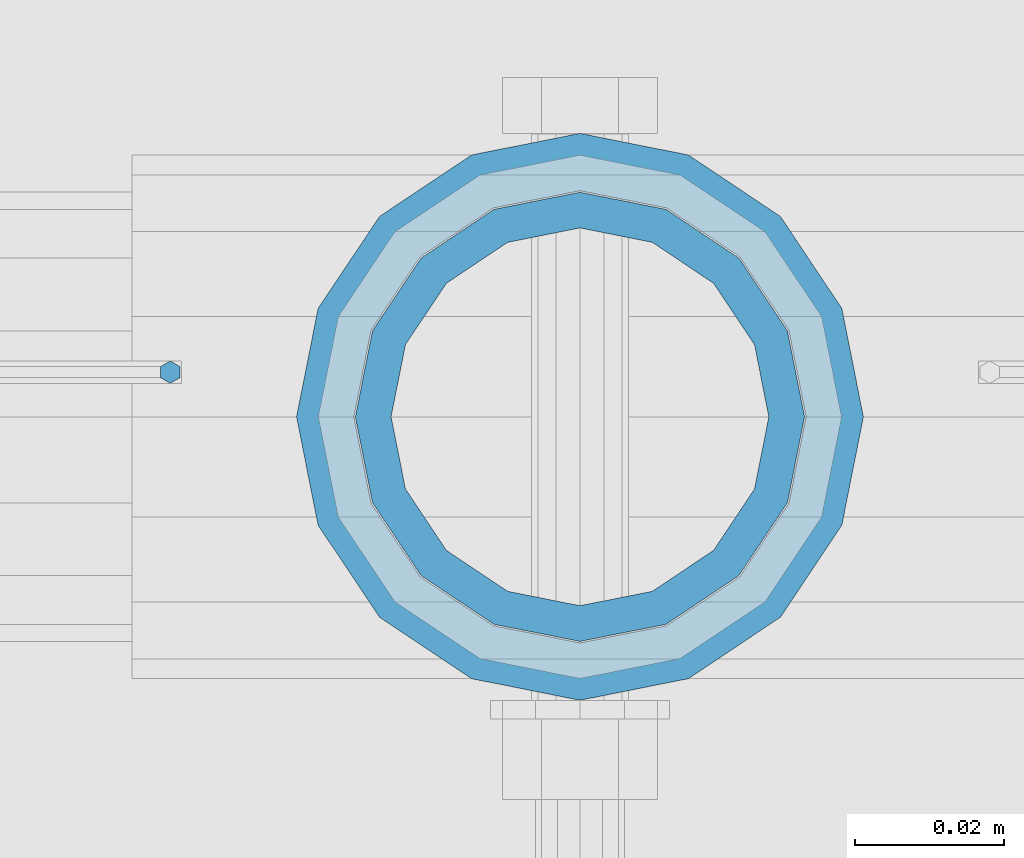
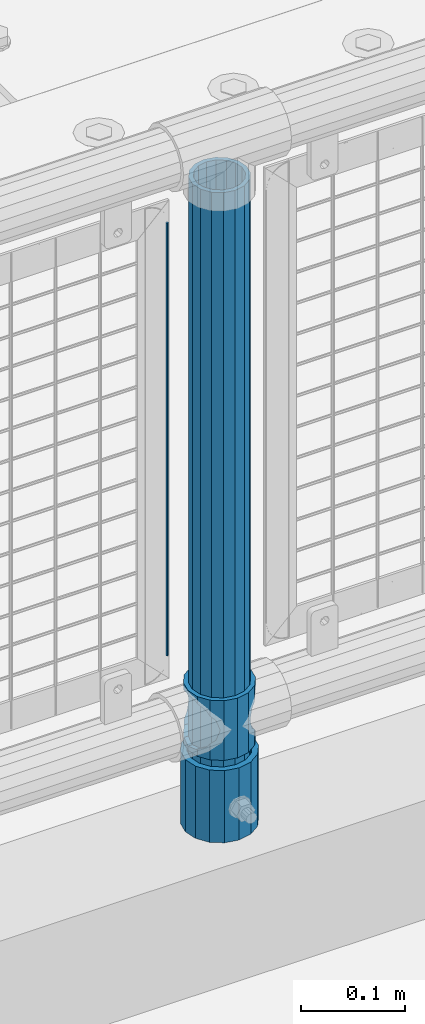
# One storey, part 82 of 247: 4 columns.
"""IFC2X3 building model written with IfcOpenShell, lengths in millimetres."""

import ifcopenshell
import ifcopenshell.guid

model = None  # the IFC model being written
_history = None  # IfcOwnerHistory: only IFC2X3 demands one
_inside = {}  # id of a spatial element -> (the spatial element, [elements in it])
_under = {}  # id of a project, library or spatial element -> (it, [spatial elements below it])
_declared = {}  # id of a project -> (the project, [libraries it declares])
_typed = {}  # id of a type object -> (the type object, [elements of that type])
_made_of = {}  # id of a material, layer set ... -> (it, [elements and type objects made of it])


def new_model(schema):
    """Start an empty IFC model of exactly this schema.

    Asked for "IFC4X3", IfcOpenShell would pick the latest addendum, in which some entities
    have other attributes; the version numbers below select the first issue.
    IFC2X3 requires an IfcOwnerHistory on every rooted entity: one is made here for all.
    """
    global model, _history
    if schema == "IFC4X3":
        model = ifcopenshell.file(schema_version=(4, 3, 0, 0))
    else:
        model = ifcopenshell.file(schema=schema)
    _inside.clear()
    _under.clear()
    _declared.clear()
    _typed.clear()
    _made_of.clear()
    _history = None
    if model.schema == "IFC2X3":
        org = make("IfcOrganization", Name="unknown")
        user = make(
            "IfcPersonAndOrganization",
            ThePerson=make("IfcPerson", FamilyName="unknown"),
            TheOrganization=org,
        )
        app = make(
            "IfcApplication",
            ApplicationDeveloper=org,
            Version="unknown",
            ApplicationFullName="unknown",
            ApplicationIdentifier="unknown",
        )
        _history = make(
            "IfcOwnerHistory",
            OwningUser=user,
            OwningApplication=app,
            ChangeAction="ADDED",
            CreationDate=0,
        )
    return model


def make(cls, **values):
    """One entity of the class cls with the attributes given. An attribute that is None is left unset."""
    return model.create_entity(
        cls, **{name: value for name, value in values.items() if value is not None}
    )


def rooted(cls, **values):
    """An entity with a GlobalId (a new one), such as an element, a storey or a relation."""
    return make(cls, GlobalId=ifcopenshell.guid.new(), OwnerHistory=_history, **values)


def si_unit(unit_type, name, prefix=None):
    """IfcSIUnit, for example si_unit("LENGTHUNIT", "METRE", prefix="MILLI")."""
    return make("IfcSIUnit", UnitType=unit_type, Prefix=prefix, Name=name)


def assignment(units):
    """IfcUnitAssignment: the units of a project."""
    return None if units is None else make("IfcUnitAssignment", Units=units)


def point(xyz):
    """IfcCartesianPoint."""
    return None if xyz is None else make("IfcCartesianPoint", Coordinates=xyz)


def direction(xyz):
    """IfcDirection."""
    return None if xyz is None else make("IfcDirection", DirectionRatios=xyz)


def frame(location, z_axis=None, x_axis=None):
    """IfcAxis2Placement3D, a coordinate frame: its origin and axes. An axis left out is left unset."""
    return make(
        "IfcAxis2Placement3D",
        Location=point(location),
        Axis=direction(z_axis),
        RefDirection=direction(x_axis),
    )


def origin_with_axes():
    """The frame at (0, 0, 0) with the z axis (0, 0, 1) and the x axis (1, 0, 0) written out."""
    return frame((0.0, 0.0, 0.0), z_axis=(0.0, 0.0, 1.0), x_axis=(1.0, 0.0, 0.0))


def place(relative_to, where):
    """IfcLocalPlacement: puts the frame where relative to a parent placement (None: the world)."""
    return make(
        "IfcLocalPlacement", PlacementRelTo=relative_to, RelativePlacement=where
    )


def context(
    kind, dimensions, precision=None, world=None, true_north=None, identifier=None
):
    """IfcGeometricRepresentationContext, for example the 3D "Model" context."""
    return make(
        "IfcGeometricRepresentationContext",
        ContextIdentifier=identifier,
        ContextType=kind,
        CoordinateSpaceDimension=dimensions,
        Precision=precision,
        WorldCoordinateSystem=world,
        TrueNorth=true_north,
    )


def subcontext(parent, identifier, kind, view, scale=None):
    """IfcGeometricRepresentationSubContext, for example "Body" below "Model"."""
    return make(
        "IfcGeometricRepresentationSubContext",
        ContextIdentifier=identifier,
        ContextType=kind,
        ParentContext=parent,
        TargetScale=scale,
        TargetView=view,
    )


def project(units=None, contexts=None):
    """IfcProject with its units and contexts."""
    return rooted(
        "IfcProject",
        Name="project",
        RepresentationContexts=contexts,
        UnitsInContext=assignment(units),
    )


def spatial(cls, under=None, at=None, **own):
    """A site, building, storey or space (cls), placed at a placement, below another one or the project."""
    s = rooted(cls, ObjectPlacement=at, **own)
    if under is not None:
        _under.setdefault(under.id(), (under, []))[1].append(s)
    return s


def faces_of(points, faces, orient=None, outer=None):
    """IfcFace entities. A face is a list of loops; a loop is a list of indices into points, from 0.

    orient and outer hold one flag for each loop. By default every Orientation is true, the
    first loop of a face is its IfcFaceOuterBound and the others are IfcFaceBound.
    """
    made = []
    for i, loops in enumerate(faces):
        bounds = []
        for j, loop in enumerate(loops):
            is_outer = j == 0 if outer is None else outer[i][j]
            bounds.append(
                make(
                    "IfcFaceOuterBound" if is_outer else "IfcFaceBound",
                    Bound=make("IfcPolyLoop", Polygon=[points[k] for k in loop]),
                    Orientation=True if orient is None else orient[i][j],
                )
            )
        made.append(make("IfcFace", Bounds=bounds))
    return made


def faceted_brep(points, faces, orient=None, outer=None, voids=None):
    """IfcFacetedBrep: a solid bounded by flat faces; with voids (closed shells), ...WithVoids."""
    shared = [point(p) for p in points]
    hull = make("IfcClosedShell", CfsFaces=faces_of(shared, faces, orient, outer))
    if voids is None:
        return make("IfcFacetedBrep", Outer=hull)
    return make(
        "IfcFacetedBrepWithVoids",
        Outer=hull,
        Voids=[
            make(cls, CfsFaces=faces_of(shared, fs, o, b)) for cls, fs, o, b in voids
        ],
    )


def shape(context_of_items, identifier, shape_type, items):
    """IfcShapeRepresentation: the items that make up one representation, for example the "Body"."""
    return make(
        "IfcShapeRepresentation",
        ContextOfItems=context_of_items,
        RepresentationIdentifier=identifier,
        RepresentationType=shape_type,
        Items=items,
    )


def material(Name=None, Category=None):
    """IfcMaterial."""
    return make("IfcMaterial", Name=Name, Category=Category)


def made_of(thing, what):
    """Note that an element or type object is made of a material, layer set ...; save() writes the relation."""
    if what is not None:
        _made_of.setdefault(what.id(), (what, []))[1].append(thing)
    return thing


def type_object(cls, material=None, **own):
    """A type object (cls), such as IfcWallType, which elements share."""
    return made_of(rooted(cls, **own), material)


def element(
    cls,
    number,
    at=None,
    inside=None,
    cuts=None,
    type_object=None,
    material=None,
    context=None,
    identifier="Body",
    shape_type=None,
    held_by="IfcProductDefinitionShape",
    body=None,
    shapes=None,
    **own,
):
    """One element of the class cls, such as IfcWall. Its Tag is "e" and its number.

    at: its placement. inside: the storey or other place that contains it. cuts: it is an
    opening in that element (IfcRelVoidsElement). A single representation is given by context,
    identifier, shape_type and body (its items); several are given by shapes. held_by: the class
    of the entity that holds the representations. save() writes the other relations.
    """
    e = rooted(cls, Tag="e%d" % number, ObjectPlacement=at, **own)
    if body is not None:
        shapes = [shape(context, identifier, shape_type, body)]
    if shapes is not None:
        e.Representation = make(held_by, Representations=shapes)
    if inside is not None:
        _inside.setdefault(inside.id(), (inside, []))[1].append(e)
    if cuts is not None:
        rooted(
            "IfcRelVoidsElement", RelatingBuildingElement=cuts, RelatedOpeningElement=e
        )
    if type_object is not None:
        _typed.setdefault(type_object.id(), (type_object, []))[1].append(e)
    return made_of(e, material)


def aggregate(whole, parts):
    """IfcRelAggregates: a whole, such as a stair, and the parts it consists of."""
    return rooted("IfcRelAggregates", RelatingObject=whole, RelatedObjects=parts)


def save(model, path):
    """Write the relations noted so far, then the file.

    IfcRelAggregates (storeys below a building ...), IfcRelContainedInSpatialStructure (elements
    in a storey), IfcRelDefinesByType, IfcRelAssociatesMaterial and IfcRelDeclares: one each for
    every whole, place, type object, material and project.
    """
    for whole, parts in _under.values():
        aggregate(whole, parts)
    for where, things in _inside.values():
        rooted(
            "IfcRelContainedInSpatialStructure",
            RelatedElements=things,
            RelatingStructure=where,
        )
    for kind, things in _typed.values():
        rooted("IfcRelDefinesByType", RelatedObjects=things, RelatingType=kind)
    for what, things in _made_of.values():
        rooted("IfcRelAssociatesMaterial", RelatedObjects=things, RelatingMaterial=what)
    for by, libraries in _declared.values():
        rooted("IfcRelDeclares", RelatingContext=by, RelatedDefinitions=libraries)
    model.write(path)


model = new_model("IFC2X3")

# Units and contexts
model_context = context("Model", 3, precision=1e-05, world=origin_with_axes())
body_context = subcontext(model_context, "Body", "Model", "MODEL_VIEW")
ifc_project = project(units=[si_unit("LENGTHUNIT", "METRE", prefix="MILLI"), si_unit("AREAUNIT", "SQUARE_METRE"), si_unit("VOLUMEUNIT", "CUBIC_METRE"), si_unit("MASSUNIT", "GRAM", prefix="KILO"), si_unit("TIMEUNIT", "SECOND"), si_unit("PLANEANGLEUNIT", "RADIAN"), si_unit("SOLIDANGLEUNIT", "STERADIAN"), si_unit("THERMODYNAMICTEMPERATUREUNIT", "DEGREE_CELSIUS"), si_unit("LUMINOUSINTENSITYUNIT", "LUMEN")], contexts=[model_context])

# Site, building, storey
site_placement = place(None, origin_with_axes())
site = spatial("IfcSite", under=ifc_project, at=site_placement, CompositionType="ELEMENT")
building_placement = place(site_placement, origin_with_axes())
building = spatial("IfcBuilding", under=site, at=building_placement, Name="Standard", CompositionType="ELEMENT")
storey_placement = place(building_placement, origin_with_axes())
storey = spatial("IfcBuildingStorey", under=building, at=storey_placement, Name="Undefined", CompositionType="ELEMENT", Elevation=0.0)

# Columns
ifc_material_1 = material()
column_type_1 = type_object("IfcColumnType", PredefinedType="NOTDEFINED")
column_1_placement = place(storey_placement, frame((7021.0, 7664.5, 168.02), z_axis=(0.0, 1.0, 0.0), x_axis=(0.0, 0.0, 1.0)))
element("IfcColumn", 1, at=column_1_placement, inside=storey, type_object=column_type_1, material=ifc_material_1, context=body_context, shape_type="Brep", body=[
    faceted_brep([(0.0, -31.75, 0.0), (0.0, -29.3331751572332, 12.1501989775916), (85.0, -29.3331751572332, 12.1501989775916), (85.0, -31.75, 0.0), (0.0, -22.4506403026735, 22.4506403026726), (85.0, -22.4506403026735, 22.4506403026726), (0.0, -12.1501989775916, 29.3331751572332), (85.0, -12.1501989775916, 29.3331751572332), (0.0, 0.0, 31.75), (85.0, 0.0, 31.75), (0.0, 12.1501989775916, 29.3331751572332), (85.0, 12.1501989775916, 29.3331751572332), (0.0, 22.4506403026735, 22.4506403026726), (85.0, 22.4506403026735, 22.4506403026726), (0.0, 29.3331751572332, 12.1501989775916), (85.0, 29.3331751572332, 12.1501989775916), (0.0, 31.75, 0.0), (85.0, 31.75, 0.0), (0.0, 29.3331751572332, -12.1501989775916), (85.0, 29.3331751572332, -12.1501989775916), (0.0, 22.4506403026735, -22.4506403026726), (85.0, 22.4506403026735, -22.4506403026726), (0.0, 12.1501989775916, -29.3331751572332), (85.0, 12.1501989775916, -29.3331751572332), (0.0, 0.0, -31.75), (85.0, 0.0, -31.75), (0.0, -12.1501989775916, -29.3331751572332), (85.0, -12.1501989775916, -29.3331751572332), (0.0, -22.4506403026735, -22.4506403026726), (85.0, -22.4506403026735, -22.4506403026726), (0.0, -29.3331751572332, -12.1501989775916), (85.0, -29.3331751572332, -12.1501989775916), (0.0, -38.0499999999993, 0.0), (0.0, -35.1536162120537, -14.5611046014919), (85.0, -35.1536162120537, -14.5611046014919), (85.0, -38.0499999999993, 0.0), (0.0, -26.9054130241475, -26.9054130241484), (85.0, -26.9054130241475, -26.9054130241484), (0.0, -14.561104601491, -35.1536162120547), (85.0, -14.561104601491, -35.1536162120547), (0.0, 0.0, -38.0500000000002), (85.0, 0.0, -38.0500000000002), (0.0, 14.561104601491, -35.1536162120547), (85.0, 14.561104601491, -35.1536162120547), (0.0, 26.9054130241475, -26.9054130241484), (85.0, 26.9054130241475, -26.9054130241484), (0.0, 35.1536162120537, -14.5611046014919), (85.0, 35.1536162120537, -14.5611046014919), (0.0, 38.0499999999993, 0.0), (85.0, 38.0499999999993, 0.0), (0.0, 35.1536162120537, 14.5611046014919), (85.0, 35.1536162120537, 14.5611046014919), (0.0, 26.9054130241475, 26.9054130241484), (85.0, 26.9054130241475, 26.9054130241484), (0.0, 14.561104601491, 35.1536162120547), (85.0, 14.561104601491, 35.1536162120547), (0.0, 0.0, 38.0500000000002), (85.0, 0.0, 38.0500000000002), (0.0, -14.561104601491, 35.1536162120547), (85.0, -14.561104601491, 35.1536162120547), (0.0, -26.9054130241475, 26.9054130241484), (85.0, -26.9054130241475, 26.9054130241484), (0.0, -35.1536162120537, 14.5611046014919), (85.0, -35.1536162120537, 14.5611046014919)], [[[0, 1, 2, 3]], [[1, 4, 5, 2]], [[4, 6, 7, 5]], [[6, 8, 9, 7]], [[8, 10, 11, 9]], [[10, 12, 13, 11]], [[12, 14, 15, 13]], [[14, 16, 17, 15]], [[16, 18, 19, 17]], [[18, 20, 21, 19]], [[20, 22, 23, 21]], [[22, 24, 25, 23]], [[24, 26, 27, 25]], [[26, 28, 29, 27]], [[28, 30, 31, 29]], [[30, 0, 3, 31]], [[32, 33, 34, 35]], [[33, 36, 37, 34]], [[36, 38, 39, 37]], [[38, 40, 41, 39]], [[40, 42, 43, 41]], [[42, 44, 45, 43]], [[44, 46, 47, 45]], [[46, 48, 49, 47]], [[48, 50, 51, 49]], [[50, 52, 53, 51]], [[52, 54, 55, 53]], [[54, 56, 57, 55]], [[56, 58, 59, 57]], [[58, 60, 61, 59]], [[60, 62, 63, 61]], [[62, 32, 35, 63]], [[37, 39, 41, 43, 45, 47, 49, 51, 53, 55, 57, 59, 61, 63, 35, 34], [5, 7, 9, 11, 13, 15, 17, 19, 21, 23, 25, 27, 29, 31, 3, 2]], [[62, 60, 58, 56, 54, 52, 50, 48, 46, 44, 42, 40, 38, 36, 33, 32], [30, 28, 26, 24, 22, 20, 18, 16, 14, 12, 10, 8, 6, 4, 1, 0]]]),
])
ifc_material_2 = material(Name="Misc_Undefined")
column_type_2 = type_object("IfcColumnType", PredefinedType="NOTDEFINED")
column_2_placement = place(storey_placement, frame((7021.0, 7664.5, 263.02), z_axis=(-1.0, 0.0, 0.0), x_axis=(0.0, 0.0, 1.0)))
element("IfcColumn", 2, at=column_2_placement, inside=storey, type_object=column_type_2, material=ifc_material_2, context=body_context, shape_type="Brep", body=[
    faceted_brep([(56.6106908090114, 21.4606908090118, -21.4606908090118), (56.6106908090114, 21.4606908090118, -27.1226768591096), (61.9623795176755, 13.4513226476329, -32.4743655677721), (63.1897438117172, 11.6144421722802, -32.839743811719), (63.1897438117172, 11.6144421722802, -28.0397438117179), (46.7644421722801, 28.0397438117179, -11.6144421722802), (46.7644421722801, 28.0397438117179, -20.088203122983), (51.5310424080055, 24.8548033587067, -24.8548033587067), (35.1499999999996, 30.35, 0.0), (35.1499999999996, 30.3500000000004, -16.6306603983649), (23.5355578277192, 28.0397438117179, -11.6144421722802), (23.5355578277192, 28.0397438117179, -20.088203122983), (13.6893091909879, 21.4606908090118, -21.4606908090118), (13.6893091909879, 21.4606908090118, -27.1226768591096), (18.768957591997, 24.8548033587067, -24.8548033587067), (7.11025618828211, 11.6144421722802, -28.0397438117179), (7.11025618828211, 11.6144421722802, -32.839743811719), (8.33762048232387, 13.4513226476329, -32.4743655677721), (4.79999999999961, 0.0, -30.3500000000004), (4.79999999999961, 0.0, -35.1499999999996), (7.11025618828211, -11.6144421722802, -28.0397438117179), (7.11025618828211, -11.6144421722802, -32.839743811719), (13.6893091909879, -21.4606908090118, -21.4606908090118), (13.6893091909879, -21.4606908090118, -27.1226768591077), (8.33762048232325, -13.4513226476329, -32.4743655677721), (23.5355578277191, -28.0397438117179, -11.6144421722802), (23.5355578277191, -28.0397438117179, -20.0882031229885), (18.768957591997, -24.8548033587067, -24.8548033587067), (35.1499999999996, -30.35, 0.0), (35.1499999999996, -30.3500000000004, -16.6306603983739), (46.7644421722801, -28.0397438117179, -11.6144421722802), (46.7644421722801, -28.0397438117179, -20.0882031229885), (56.6106908090114, -21.4606908090118, -21.4606908090118), (56.6106908090114, -21.4606908090118, -27.1226768591077), (51.5310424080038, -24.8548033587067, -24.8548033587067), (63.1897438117172, -11.6144421722802, -28.0397438117179), (63.1897438117172, -11.6144421722802, -32.839743811719), (61.9623795176754, -13.4513226476329, -32.4743655677721), (65.4999999999997, 0.0, -30.3500000000004), (65.4999999999997, 0.0, -35.1499999999996), (0.0, -28.0397438117179, -11.6144421722802), (0.0, -30.3500000000004, 0.0), (0.0, -21.4606908090118, -21.4606908090118), (0.0, -11.6144421722802, -28.0397438117179), (0.0, 0.0, -30.3500000000004), (0.0, 11.6144421722802, -28.0397438117179), (0.0, 21.4606908090118, -21.4606908090118), (0.0, 28.0397438117179, -11.6144421722802), (0.0, 30.3500000000004, 0.0), (0.0, 28.0397438117179, 11.6144421722802), (23.5355578277192, 28.0397438117179, 11.6144421722806), (0.0, 21.4606908090118, 21.4606908090118), (13.6893091909879, 21.4606908090118, 21.4606908090118), (0.0, 11.6144421722802, 28.0397438117179), (7.11025618828211, 11.6144421722802, 28.0397438117175), (0.0, 0.0, 30.3500000000004), (4.79999999999961, 0.0, 30.3499999999999), (0.0, -11.6144421722802, 28.0397438117179), (7.11025618828205, -11.6144421722802, 28.0397438117175), (0.0, -21.4606908090118, 21.4606908090118), (13.6893091909879, -21.4606908090118, 21.4606908090118), (0.0, -28.0397438117179, 11.6144421722802), (23.5355578277191, -28.0397438117179, 11.6144421722806), (0.0, -32.4743655677721, 13.4513226476338), (0.0, -35.1499999999996, 0.0), (70.2999999999993, -35.1499999999996, 0.0), (70.2999999999993, -32.4743655677721, 13.4513226476338), (0.0, 13.4513226476329, -32.4743655677721), (0.0, 24.8548033587067, -24.8548033587067), (0.0, 0.0, -35.1499999999996), (0.0, -13.4513226476329, -32.4743655677721), (0.0, -24.8548033587067, -24.8548033587067), (0.0, -24.8548033587067, 24.8548033587067), (0.0, -13.4513226476329, 32.4743655677721), (0.0, 0.0, 35.1499999999996), (0.0, 13.4513226476329, 32.4743655677721), (0.0, 24.8548033587067, 24.8548033587067), (0.0, 32.4743655677721, 13.4513226476338), (0.0, 35.1499999999996, 0.0), (0.0, 32.4743655677721, -13.4513226476338), (0.0, -32.4743655677721, -13.4513226476338), (70.2999999999993, 32.4743655677721, 13.4513226476338), (70.2999999999993, 35.1499999999996, 0.0), (70.2999999999993, 32.4743655677721, -13.4513226476338), (70.2999999999993, 24.8548033587067, -24.8548033587067), (70.2999999999993, 13.4513226476329, -32.4743655677721), (70.2999999999993, 0.0, -35.1499999999996), (70.2999999999993, -13.4513226476329, -32.4743655677721), (70.2999999999993, -24.8548033587067, -24.8548033587067), (70.2999999999993, -32.4743655677721, -13.4513226476338), (70.2999999999993, 28.0397438117179, 11.6144421722802), (70.2999999999993, 21.4606908090118, 21.4606908090118), (56.6106908090114, 21.4606908090118, 21.4606908090118), (46.7644421722801, 28.0397438117179, 11.6144421722806), (70.2999999999993, 11.6144421722802, 28.0397438117179), (63.1897438117172, 11.6144421722802, 28.0397438117175), (70.2999999999993, 0.0, 30.3500000000004), (65.4999999999997, 0.0, 30.3499999999999), (70.2999999999993, -11.6144421722802, 28.0397438117179), (63.1897438117172, -11.6144421722802, 28.0397438117175), (70.2999999999993, -21.4606908090118, 21.4606908090118), (56.6106908090114, -21.4606908090118, 21.4606908090118), (70.2999999999993, -28.0397438117179, 11.6144421722802), (46.7644421722801, -28.0397438117179, 11.6144421722806), (70.2999999999993, -11.6144421722802, -28.0397438117179), (70.2999999999993, 0.0, -30.3500000000004), (70.2999999999993, -21.4606908090118, -21.4606908090118), (70.2999999999993, -28.0397438117179, -11.6144421722802), (70.2999999999993, -30.3500000000004, 0.0), (70.2999999999993, 24.8548033587067, 24.8548033587067), (70.2999999999993, 13.4513226476329, 32.4743655677721), (70.2999999999993, 0.0, 35.1499999999996), (70.2999999999993, -13.4513226476329, 32.4743655677721), (70.2999999999993, -24.8548033587067, 24.8548033587067), (70.2999999999993, 30.3500000000004, 0.0), (70.2999999999993, 28.0397438117179, -11.6144421722802), (70.2999999999993, 21.4606908090118, -21.4606908090118), (70.2999999999993, 11.6144421722802, -28.0397438117179), (61.9623795176755, 13.4513226476329, 32.4743655677717), (51.5310424080043, 24.8548033587067, 24.8548033587072), (56.6106908090114, 21.4606908090118, 27.1226768591082), (65.4999999999997, 0.0, 35.1500000000001), (63.1897438117172, 11.6144421722802, 32.8397438117177), (63.1897438117172, -11.6144421722802, 32.8397438117177), (61.962379517675, -13.4513226476329, 32.4743655677717), (56.6106908090114, -21.4606908090118, 27.1226768591068), (51.5310424080026, -24.8548033587067, 24.8548033587072), (18.7689575919956, -24.8548033587067, 24.8548033587072), (46.7644421722801, -28.0397438117179, 20.088203122983), (35.1499999999996, -30.3500000000004, 16.6306603983649), (23.5355578277191, -28.0397438117179, 20.088203122983), (8.33762048232268, -13.4513226476329, 32.4743655677717), (13.6893091909879, -21.4606908090118, 27.1226768591068), (4.79999999999961, 0.0, 35.1500000000001), (7.11025618828205, -11.6144421722802, 32.8397438117177), (7.11025618828211, 11.6144421722802, 32.8397438117177), (8.33762048232427, 13.4513226476329, 32.4743655677717), (13.6893091909879, 21.4606908090118, 27.1226768591082), (18.7689575919966, 24.8548033587067, 24.8548033587072), (23.5355578277192, 28.0397438117179, 20.0882031229844), (35.1499999999996, 30.3500000000004, 16.6306603983667), (46.7644421722801, 28.0397438117179, 20.0882031229844)], [[[0, 1, 2, 3, 4]], [[5, 6, 7, 1, 0]], [[8, 9, 6, 5]], [[10, 11, 9, 8]], [[12, 13, 14, 11, 10]], [[15, 16, 17, 13, 12]], [[18, 19, 16, 15]], [[20, 21, 19, 18]], [[22, 23, 24, 21, 20]], [[25, 26, 27, 23, 22]], [[28, 29, 26, 25]], [[30, 31, 29, 28]], [[32, 33, 34, 31, 30]], [[35, 36, 37, 33, 32]], [[38, 39, 36, 35]], [[4, 3, 39, 38]], [[40, 41, 28, 25]], [[42, 40, 25, 22]], [[43, 42, 22, 20]], [[44, 43, 20, 18]], [[45, 44, 18, 15]], [[46, 45, 15, 12]], [[47, 46, 12, 10]], [[48, 47, 10, 8]], [[49, 48, 8, 50]], [[51, 49, 50, 52]], [[53, 51, 52, 54]], [[55, 53, 54, 56]], [[57, 55, 56, 58]], [[59, 57, 58, 60]], [[61, 59, 60, 62]], [[41, 61, 62, 28]], [[63, 64, 65, 66]], [[17, 67, 68, 14, 13]], [[19, 69, 67, 17, 16]], [[70, 69, 19, 21, 24]], [[71, 70, 24, 23, 27]], [[63, 72, 73, 74, 75, 76, 77, 78, 79, 68, 67, 69, 70, 71, 80, 64], [40, 42, 43, 44, 45, 46, 47, 48, 49, 51, 53, 55, 57, 59, 61, 41]], [[78, 77, 81, 82]], [[79, 78, 82, 83]], [[14, 68, 79, 83, 84, 7, 6, 9, 11]], [[84, 85, 2, 1, 7]], [[85, 86, 39, 3, 2]], [[37, 87, 88, 34, 33]], [[39, 86, 87, 37, 36]], [[34, 88, 89, 80, 71, 27, 26, 29, 31]], [[64, 80, 89, 65]], [[90, 91, 92, 93]], [[91, 94, 95, 92]], [[94, 96, 97, 95]], [[96, 98, 99, 97]], [[98, 100, 101, 99]], [[100, 102, 103, 101]], [[104, 105, 38, 35]], [[106, 104, 35, 32]], [[107, 106, 32, 30]], [[108, 107, 30, 28]], [[102, 108, 28, 103]], [[88, 87, 86, 85, 84, 83, 82, 81, 109, 110, 111, 112, 113, 66, 65, 89], [100, 98, 96, 94, 91, 90, 114, 115, 116, 117, 105, 104, 106, 107, 108, 102]], [[118, 110, 109, 119, 120]], [[121, 111, 110, 118, 122]], [[112, 111, 121, 123, 124]], [[113, 112, 124, 125, 126]], [[127, 72, 63, 66, 113, 126, 128, 129, 130]], [[131, 73, 72, 127, 132]], [[133, 74, 73, 131, 134]], [[75, 74, 133, 135, 136]], [[76, 75, 136, 137, 138]], [[119, 109, 81, 77, 76, 138, 139, 140, 141]], [[92, 120, 119, 141, 93]], [[95, 122, 118, 120, 92]], [[97, 121, 122, 95]], [[99, 123, 121, 97]], [[101, 125, 124, 123, 99]], [[103, 128, 126, 125, 101]], [[28, 129, 128, 103]], [[62, 130, 129, 28]], [[60, 132, 127, 130, 62]], [[58, 134, 131, 132, 60]], [[56, 133, 134, 58]], [[54, 135, 133, 56]], [[52, 137, 136, 135, 54]], [[50, 139, 138, 137, 52]], [[8, 140, 139, 50]], [[93, 141, 140, 8]], [[114, 90, 93, 8]], [[115, 114, 8, 5]], [[116, 115, 5, 0]], [[117, 116, 0, 4]], [[105, 117, 4, 38]]]),
])
column_type_3 = type_object("IfcColumnType", PredefinedType="NOTDEFINED")
column_3_placement = place(storey_placement, frame((7021.0, 7664.5, 168.02), z_axis=(-1.0, 0.0, 0.0), x_axis=(0.0, 0.0, 1.0)))
element("IfcColumn", 3, at=column_3_placement, inside=storey, type_object=column_type_3, material=ifc_material_1, context=body_context, shape_type="Brep", body=[
    faceted_brep([(0.0, -25.3500000000004, 0.0), (0.0, -23.4203461491616, 9.70102501045585), (760.0, -23.4203461491616, 9.70102501045585), (760.0, -25.3500000000004, 0.0), (0.0, -17.9251569030794, 17.9251569030785), (760.0, -17.9251569030794, 17.9251569030785), (0.0, -9.70102501045494, 23.4203461491616), (760.0, -9.70102501045494, 23.4203461491616), (0.0, 0.0, 25.3500000000004), (760.0, 0.0, 25.3500000000004), (0.0, 9.70102501045494, 23.4203461491616), (760.0, 9.70102501045494, 23.4203461491616), (0.0, 17.9251569030794, 17.9251569030785), (760.0, 17.9251569030794, 17.9251569030785), (0.0, 23.4203461491616, 9.70102501045585), (760.0, 23.4203461491616, 9.70102501045585), (0.0, 25.3500000000004, 0.0), (760.0, 25.3500000000004, 0.0), (0.0, 23.4203461491616, -9.70102501045585), (760.0, 23.4203461491616, -9.70102501045585), (0.0, 17.9251569030794, -17.9251569030785), (760.0, 17.9251569030794, -17.9251569030785), (0.0, 9.70102501045494, -23.4203461491616), (760.0, 9.70102501045494, -23.4203461491616), (0.0, 0.0, -25.3500000000004), (760.0, 0.0, -25.3500000000004), (0.0, -9.70102501045494, -23.4203461491616), (760.0, -9.70102501045494, -23.4203461491616), (0.0, -17.9251569030794, -17.9251569030785), (760.0, -17.9251569030794, -17.9251569030785), (0.0, -23.4203461491616, -9.70102501045585), (760.0, -23.4203461491616, -9.70102501045585), (0.0, -30.1499999999996, 0.0), (0.0, -27.8549679052148, -11.5379054858076), (760.0, -27.8549679052148, -11.5379054858076), (760.0, -30.1499999999996, 0.0), (0.0, -21.3192694527743, -21.3192694527752), (760.0, -21.3192694527743, -21.3192694527752), (0.0, -11.5379054858076, -27.8549679052157), (760.0, -11.5379054858076, -27.8549679052157), (0.0, 0.0, -30.1499999999996), (760.0, 0.0, -30.1499999999996), (0.0, 11.5379054858076, -27.8549679052157), (760.0, 11.5379054858076, -27.8549679052157), (0.0, 21.3192694527743, -21.3192694527752), (760.0, 21.3192694527743, -21.3192694527752), (0.0, 27.8549679052157, -11.5379054858076), (760.0, 27.8549679052157, -11.5379054858076), (0.0, 30.1499999999996, 0.0), (760.0, 30.1499999999996, 0.0), (0.0, 27.8549679052157, 11.5379054858076), (760.0, 27.8549679052157, 11.5379054858076), (0.0, 21.3192694527743, 21.3192694527752), (760.0, 21.3192694527743, 21.3192694527752), (0.0, 11.5379054858076, 27.8549679052157), (760.0, 11.5379054858076, 27.8549679052157), (0.0, 0.0, 30.1499999999996), (760.0, 0.0, 30.1499999999996), (0.0, -11.5379054858076, 27.8549679052157), (760.0, -11.5379054858076, 27.8549679052157), (0.0, -21.3192694527743, 21.3192694527752), (760.0, -21.3192694527743, 21.3192694527752), (0.0, -27.8549679052157, 11.5379054858076), (760.0, -27.8549679052157, 11.5379054858076)], [[[0, 1, 2, 3]], [[1, 4, 5, 2]], [[4, 6, 7, 5]], [[6, 8, 9, 7]], [[8, 10, 11, 9]], [[10, 12, 13, 11]], [[12, 14, 15, 13]], [[14, 16, 17, 15]], [[16, 18, 19, 17]], [[18, 20, 21, 19]], [[20, 22, 23, 21]], [[22, 24, 25, 23]], [[24, 26, 27, 25]], [[26, 28, 29, 27]], [[28, 30, 31, 29]], [[30, 0, 3, 31]], [[32, 33, 34, 35]], [[33, 36, 37, 34]], [[36, 38, 39, 37]], [[38, 40, 41, 39]], [[40, 42, 43, 41]], [[42, 44, 45, 43]], [[44, 46, 47, 45]], [[46, 48, 49, 47]], [[48, 50, 51, 49]], [[50, 52, 53, 51]], [[52, 54, 55, 53]], [[54, 56, 57, 55]], [[56, 58, 59, 57]], [[58, 60, 61, 59]], [[60, 62, 63, 61]], [[62, 32, 35, 63]], [[37, 39, 41, 43, 45, 47, 49, 51, 53, 55, 57, 59, 61, 63, 35, 34], [5, 7, 9, 11, 13, 15, 17, 19, 21, 23, 25, 27, 29, 31, 3, 2]], [[62, 60, 58, 56, 54, 52, 50, 48, 46, 44, 42, 40, 38, 36, 33, 32], [30, 28, 26, 24, 22, 20, 18, 16, 14, 12, 10, 8, 6, 4, 1, 0]]]),
])
column_type_4 = type_object("IfcColumnType", Name="D3", PredefinedType="NOTDEFINED")
column_4_placement = place(storey_placement, frame((6966.0, 7670.5, 378.020000000001), z_axis=(-1.0, 0.0, 0.0), x_axis=(0.0, 0.0, 1.0)))
element("IfcColumn", 4, at=column_4_placement, inside=storey, type_object=column_type_4, material=ifc_material_2, ObjectType="D3", context=body_context, shape_type="Brep", body=[
    faceted_brep([(1.81898940354586e-12, -1.5, -5.6843418860808e-14), (0.0, -0.75, -1.29903810567703), (510.0, -0.75, -1.29903810567703), (510.0, -1.5, 0.0), (0.0, 0.75, -1.29903810567703), (510.0, 0.75, -1.29903810567703), (1.81898940354586e-12, 1.5, -5.6843418860808e-14), (510.0, 1.5, 0.0), (0.0, 0.75, 1.29903810567703), (510.0, 0.75, 1.29903810567703), (0.0, -0.75, 1.29903810567703), (510.0, -0.75, 1.29903810567703)], [[[0, 1, 2, 3]], [[1, 4, 5, 2]], [[4, 6, 7, 5]], [[6, 8, 9, 7]], [[8, 10, 11, 9]], [[10, 0, 3, 11]], [[5, 7, 9, 11, 3, 2]], [[10, 8, 6, 4, 1, 0]]]),
])

save(model, "model.ifc")
